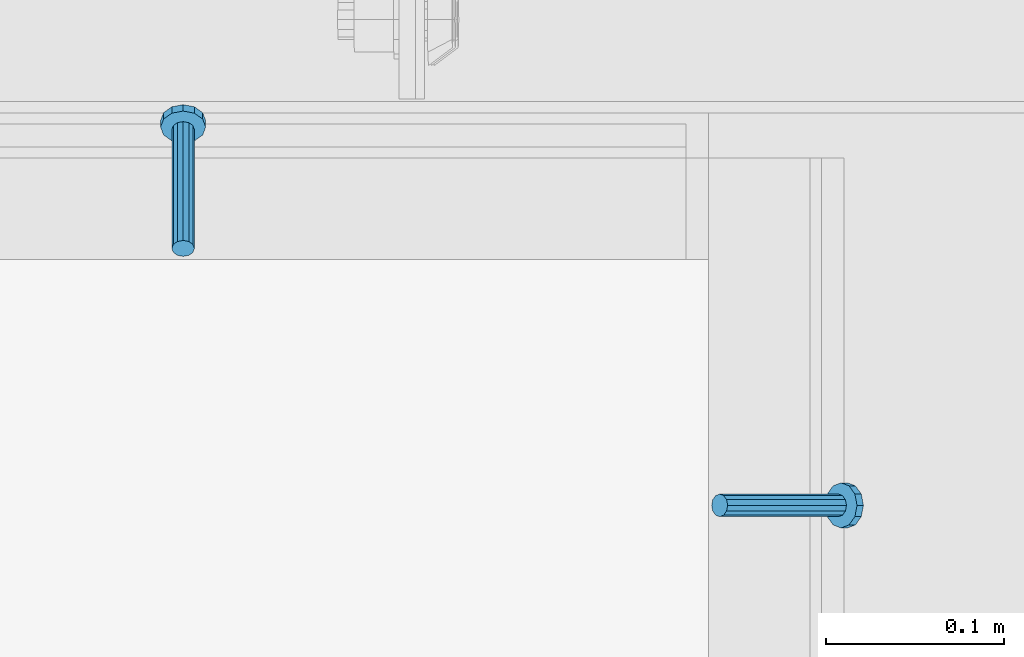
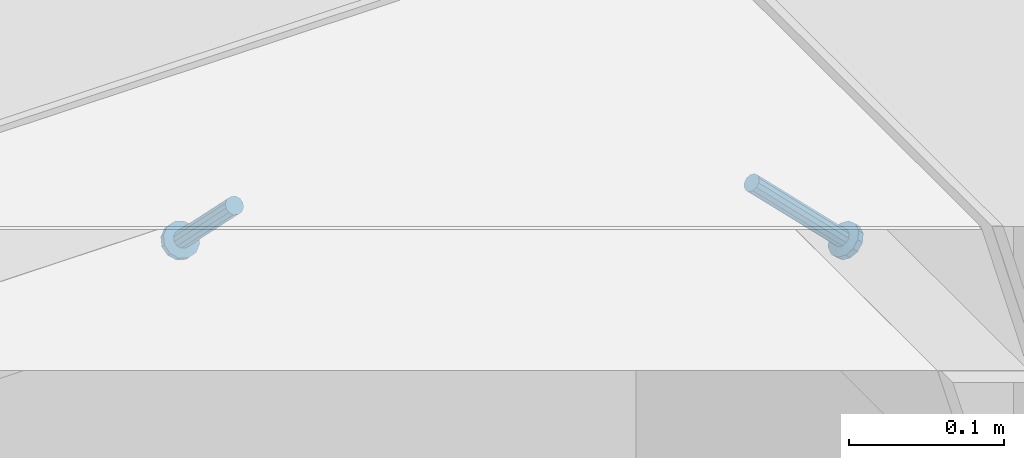
# One storey, part 2114 of 3843: 2 members, 2 elements without a shape of their own.
"""IFC2X3 building model written with IfcOpenShell, lengths in millimetres."""

from ifc_helpers import new_model, si_unit, frame, origin_with_axes, place, context, subcontext, project, spatial, faceted_brep, material, type_object, element, aggregate, save


model = new_model("IFC2X3")

# Units and contexts
model_context = context("Model", 3, precision=1e-05, world=origin_with_axes())
body_context = subcontext(model_context, "Body", "Model", "MODEL_VIEW")
ifc_project = project(units=[si_unit("LENGTHUNIT", "METRE", prefix="MILLI"), si_unit("AREAUNIT", "SQUARE_METRE"), si_unit("VOLUMEUNIT", "CUBIC_METRE"), si_unit("MASSUNIT", "GRAM", prefix="KILO"), si_unit("TIMEUNIT", "SECOND"), si_unit("PLANEANGLEUNIT", "RADIAN"), si_unit("SOLIDANGLEUNIT", "STERADIAN"), si_unit("THERMODYNAMICTEMPERATUREUNIT", "DEGREE_CELSIUS"), si_unit("LUMINOUSINTENSITYUNIT", "LUMEN")], contexts=[model_context])

# Site, building, storey
site_placement = place(None, origin_with_axes())
site = spatial("IfcSite", under=ifc_project, at=site_placement, CompositionType="ELEMENT")
building_placement = place(site_placement, origin_with_axes())
building = spatial("IfcBuilding", under=site, at=building_placement, Name="Undefined", CompositionType="ELEMENT")
storey_placement = place(building_placement, origin_with_axes())
storey = spatial("IfcBuildingStorey", under=building, at=storey_placement, Name="Undefined", CompositionType="ELEMENT", Elevation=0.0)

# Assembly, member
assembly_1_placement = place(storey_placement, origin_with_axes())
assembly_1 = element("IfcElementAssembly", 1, at=assembly_1_placement, inside=storey, Name="ANGLE", AssemblyPlace="NOTDEFINED", PredefinedType="RIGID_FRAME")
ifc_material = material(Name="STEEL/A108")
member_type = type_object("IfcMemberType", PredefinedType="NOTDEFINED")
member_1_placement = place(assembly_1_placement, frame((50590.4414794922, 24930.0999999984, 30397.4500030518), z_axis=(-1.0, 0.0, 0.0), x_axis=(5.70000238222118e-08, 0.707106781186546, -0.707106781186546)))
member_1 = element("IfcMember", 2, at=member_1_placement, type_object=member_type, material=ifc_material, Name="HEADED STUD ANCHOR", context=body_context, shape_type="Brep", body=[
    faceted_brep([(7.27595761418343e-12, -3.18000006675175, 5.5), (0.0, -5.49999999998363, 3.1800000667572), (94.4879985803855, -5.50000000011278, 3.1800000667572), (94.4879985803782, -3.18000006687362, 5.5), (0.0, -6.3499999046162, 0.0), (94.4879985803855, -6.34999990474535, 0.0), (0.0, -5.49999999998363, -3.1800000667572), (94.4879985803855, -5.50000000011278, -3.1800000667572), (7.27595761418343e-12, -3.18000006675175, -5.5), (94.4879985803782, -3.18000006687362, -5.5), (7.27595761418343e-12, -1.81898940354586e-12, -6.34999990463257), (94.4879985803782, -1.20053300634027e-10, -6.34999990463257), (0.0, 3.18000006675175, -5.5), (94.4879985803709, 3.18000006663351, -5.5), (7.27595761418343e-12, 5.49999999998363, -3.1800000667572), (94.4879985803709, 5.49999999987267, -3.1800000667572), (7.27595761418343e-12, 6.3499999046162, 0.0), (94.4879985803673, 6.34999990450706, 0.0), (7.27595761418343e-12, 5.49999999998363, 3.1800000667572), (94.4879985803709, 5.49999999987267, 3.1800000667572), (0.0, 3.18000006675175, 5.5), (94.4879985803709, 3.18000006663351, 5.5), (7.27595761418343e-12, -1.81898940354586e-12, 6.34999990463257), (94.4879985803782, -1.20053300634027e-10, 6.34999990463257), (96.5199985498621, -10.9899997712273, 6.34999990463257), (96.5199985498548, -6.34000015270249, 10.9899997711182), (96.5199985498621, -12.6999998093743, 0.0), (96.5199985498621, -10.9899997712273, -6.34999990463257), (96.5199985498548, -6.34000015270249, -10.9899997711182), (96.5199985498475, -1.21872290037572e-10, -12.6899995803833), (96.5199985498402, 6.34000015245874, -10.9899997711182), (96.519998549833, 10.9899997709817, -6.34999990463257), (96.519998549833, 12.6999998091305, 0.0), (96.519998549833, 10.9899997709817, 6.34999990463257), (96.5199985498402, 6.34000015245874, 10.9899997711182), (96.5199985498475, -1.21872290037572e-10, 12.6899995803833), (101.599998473539, -10.9899997712328, 6.34999990463257), (101.599998473532, -6.34000015270976, 10.9899997711182), (101.599998473539, -12.6999998093797, 0.0), (101.599998473539, -10.9899997712328, -6.34999990463257), (101.599998473532, -6.34000015270976, -10.9899997711182), (101.599998473524, -1.29148247651756e-10, -12.6899995803833), (101.599998473517, 6.34000015245329, -10.9899997711182), (101.59999847351, 10.9899997709763, -6.34999990463257), (101.599998473503, 12.6999998091196, 0.0), (101.59999847351, 10.9899997709763, 6.34999990463257), (101.599998473517, 6.34000015245329, 10.9899997711182), (101.599998473524, -1.29148247651756e-10, 12.6899995803833)], [[[0, 1, 2, 3]], [[1, 4, 5, 2]], [[4, 6, 7, 5]], [[6, 8, 9, 7]], [[8, 10, 11, 9]], [[10, 12, 13, 11]], [[12, 14, 15, 13]], [[14, 16, 17, 15]], [[16, 18, 19, 17]], [[18, 20, 21, 19]], [[20, 22, 23, 21]], [[22, 0, 3, 23]], [[22, 20, 18, 16, 14, 12, 10, 8, 6, 4, 1, 0]], [[3, 2, 24, 25]], [[2, 5, 26, 24]], [[5, 7, 27, 26]], [[7, 9, 28, 27]], [[9, 11, 29, 28]], [[11, 13, 30, 29]], [[13, 15, 31, 30]], [[15, 17, 32, 31]], [[17, 19, 33, 32]], [[19, 21, 34, 33]], [[21, 23, 35, 34]], [[23, 3, 25, 35]], [[25, 24, 36, 37]], [[24, 26, 38, 36]], [[26, 27, 39, 38]], [[27, 28, 40, 39]], [[28, 29, 41, 40]], [[29, 30, 42, 41]], [[30, 31, 43, 42]], [[31, 32, 44, 43]], [[32, 33, 45, 44]], [[33, 34, 46, 45]], [[34, 35, 47, 46]], [[35, 25, 37, 47]], [[38, 39, 40, 41, 42, 43, 44, 45, 46, 47, 37, 36]]]),
])
aggregate(assembly_1, [member_1])

assembly_2_placement = place(storey_placement, origin_with_axes())
assembly_2 = element("IfcElementAssembly", 3, at=assembly_2_placement, inside=storey, Name="ANGLE", AssemblyPlace="NOTDEFINED", PredefinedType="RIGID_FRAME")
member_2_placement = place(assembly_2_placement, frame((50892.075, 24785.6375, 30397.4500030517), z_axis=(0.0, 1.0, 0.0), x_axis=(0.707106781186548, 0.0, -0.707106781186548)))
member_2 = element("IfcMember", 4, at=member_2_placement, type_object=member_type, material=ifc_material, Name="HEADED STUD ANCHOR", context=body_context, shape_type="Brep", body=[
    faceted_brep([(7.27595761418343e-12, -3.18000006675175, 5.5), (0.0, -5.49999999998363, 3.1800000667572), (94.4879985803855, -5.50000000011278, 3.1800000667572), (94.4879985803782, -3.18000006687362, 5.5), (0.0, -6.3499999046162, 0.0), (94.4879985803855, -6.34999990474535, 0.0), (0.0, -5.49999999998363, -3.1800000667572), (94.4879985803855, -5.50000000011278, -3.1800000667572), (7.27595761418343e-12, -3.18000006675175, -5.5), (94.4879985803782, -3.18000006687362, -5.5), (7.27595761418343e-12, -1.81898940354586e-12, -6.34999990463257), (94.4879985803782, -1.20053300634027e-10, -6.34999990463257), (0.0, 3.18000006675175, -5.5), (94.4879985803709, 3.18000006663351, -5.5), (7.27595761418343e-12, 5.49999999998363, -3.1800000667572), (94.4879985803709, 5.49999999987267, -3.1800000667572), (7.27595761418343e-12, 6.3499999046162, 0.0), (94.4879985803673, 6.34999990450706, 0.0), (7.27595761418343e-12, 5.49999999998363, 3.1800000667572), (94.4879985803709, 5.49999999987267, 3.1800000667572), (0.0, 3.18000006675175, 5.5), (94.4879985803709, 3.18000006663351, 5.5), (7.27595761418343e-12, -1.81898940354586e-12, 6.34999990463257), (94.4879985803782, -1.20053300634027e-10, 6.34999990463257), (96.5199985498621, -10.9899997712273, 6.34999990463257), (96.5199985498548, -6.34000015270249, 10.9899997711182), (96.5199985498621, -12.6999998093743, 0.0), (96.5199985498621, -10.9899997712273, -6.34999990463257), (96.5199985498548, -6.34000015270249, -10.9899997711182), (96.5199985498475, -1.21872290037572e-10, -12.6899995803833), (96.5199985498402, 6.34000015245874, -10.9899997711182), (96.519998549833, 10.9899997709817, -6.34999990463257), (96.519998549833, 12.6999998091305, 0.0), (96.519998549833, 10.9899997709817, 6.34999990463257), (96.5199985498402, 6.34000015245874, 10.9899997711182), (96.5199985498475, -1.21872290037572e-10, 12.6899995803833), (101.599998473539, -10.9899997712328, 6.34999990463257), (101.599998473532, -6.34000015270976, 10.9899997711182), (101.599998473539, -12.6999998093797, 0.0), (101.599998473539, -10.9899997712328, -6.34999990463257), (101.599998473532, -6.34000015270976, -10.9899997711182), (101.599998473524, -1.29148247651756e-10, -12.6899995803833), (101.599998473517, 6.34000015245329, -10.9899997711182), (101.59999847351, 10.9899997709763, -6.34999990463257), (101.599998473503, 12.6999998091196, 0.0), (101.59999847351, 10.9899997709763, 6.34999990463257), (101.599998473517, 6.34000015245329, 10.9899997711182), (101.599998473524, -1.29148247651756e-10, 12.6899995803833)], [[[0, 1, 2, 3]], [[1, 4, 5, 2]], [[4, 6, 7, 5]], [[6, 8, 9, 7]], [[8, 10, 11, 9]], [[10, 12, 13, 11]], [[12, 14, 15, 13]], [[14, 16, 17, 15]], [[16, 18, 19, 17]], [[18, 20, 21, 19]], [[20, 22, 23, 21]], [[22, 0, 3, 23]], [[22, 20, 18, 16, 14, 12, 10, 8, 6, 4, 1, 0]], [[3, 2, 24, 25]], [[2, 5, 26, 24]], [[5, 7, 27, 26]], [[7, 9, 28, 27]], [[9, 11, 29, 28]], [[11, 13, 30, 29]], [[13, 15, 31, 30]], [[15, 17, 32, 31]], [[17, 19, 33, 32]], [[19, 21, 34, 33]], [[21, 23, 35, 34]], [[23, 3, 25, 35]], [[25, 24, 36, 37]], [[24, 26, 38, 36]], [[26, 27, 39, 38]], [[27, 28, 40, 39]], [[28, 29, 41, 40]], [[29, 30, 42, 41]], [[30, 31, 43, 42]], [[31, 32, 44, 43]], [[32, 33, 45, 44]], [[33, 34, 46, 45]], [[34, 35, 47, 46]], [[35, 25, 37, 47]], [[38, 39, 40, 41, 42, 43, 44, 45, 46, 47, 37, 36]]]),
])
aggregate(assembly_2, [member_2])

save(model, "model.ifc")
